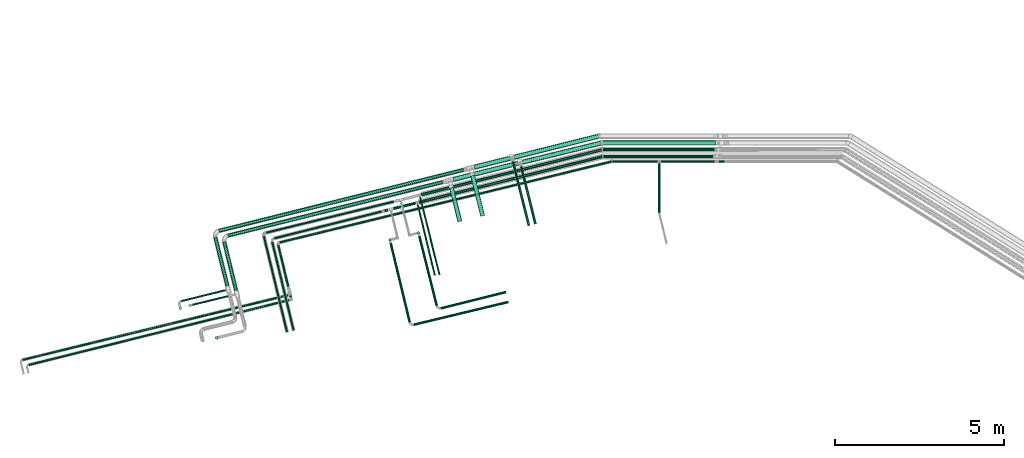
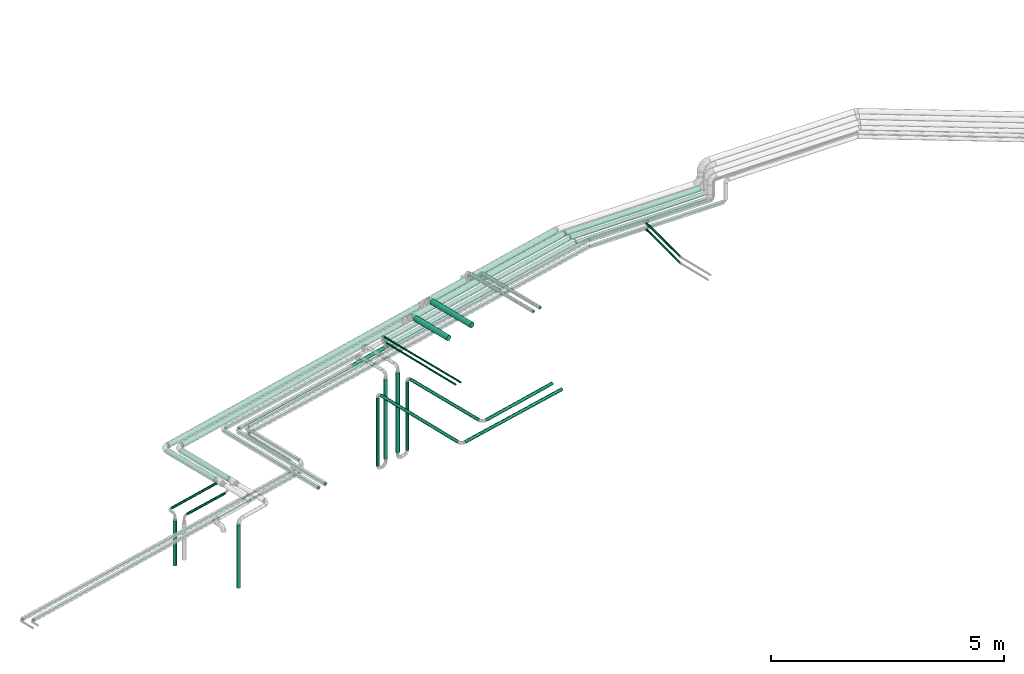
# One storey, part 42 of 93: 48 flow segments.
"""IFC2X3 building model written with IfcOpenShell, lengths in millimetres."""

from ifc_helpers import new_model, entity, si_unit, converted_unit, derived_unit, direction, frame, origin, origin_2d_with_axis, place, context, subcontext, project, spatial, polyline, circle, outline, extrude, type_object, element, save


model = new_model("IFC2X3")

# Units and contexts
model_context = context("Model", 3, precision=0.01, world=origin(), true_north=direction((6.12303176911189e-17, 1.0)))
body_context = subcontext(model_context, "Body", "Model", "MODEL_VIEW")
ifc_project = project(units=[si_unit("LENGTHUNIT", "METRE", prefix="MILLI"), si_unit("AREAUNIT", "SQUARE_METRE"), si_unit("VOLUMEUNIT", "CUBIC_METRE"), converted_unit("PLANEANGLEUNIT", "DEGREE", entity("IfcRatioMeasure", 0.0174532925199433), si_unit("PLANEANGLEUNIT", "RADIAN"), dimensions=[0, 0, 0, 0, 0, 0, 0]), si_unit("MASSUNIT", "GRAM", prefix="KILO"), derived_unit("MASSDENSITYUNIT", [(si_unit("MASSUNIT", "GRAM", prefix="KILO"), 1), (si_unit("LENGTHUNIT", "METRE"), -3)]), derived_unit("MOMENTOFINERTIAUNIT", [(si_unit("LENGTHUNIT", "METRE"), 4)]), si_unit("TIMEUNIT", "SECOND"), si_unit("FREQUENCYUNIT", "HERTZ"), si_unit("THERMODYNAMICTEMPERATUREUNIT", "DEGREE_CELSIUS"), derived_unit("THERMALTRANSMITTANCEUNIT", [(si_unit("MASSUNIT", "GRAM", prefix="KILO"), 1), (si_unit("THERMODYNAMICTEMPERATUREUNIT", "KELVIN"), -1), (si_unit("TIMEUNIT", "SECOND"), -3)]), derived_unit("VOLUMETRICFLOWRATEUNIT", [(si_unit("LENGTHUNIT", "METRE"), 3), (si_unit("TIMEUNIT", "SECOND"), -1)]), derived_unit("MASSFLOWRATEUNIT", [(si_unit("MASSUNIT", "GRAM", prefix="KILO"), 1), (si_unit("TIMEUNIT", "SECOND"), -1)]), derived_unit("ROTATIONALFREQUENCYUNIT", [(si_unit("TIMEUNIT", "SECOND"), -1)]), si_unit("ELECTRICCURRENTUNIT", "AMPERE"), si_unit("ELECTRICVOLTAGEUNIT", "VOLT"), si_unit("POWERUNIT", "WATT"), si_unit("FORCEUNIT", "NEWTON", prefix="KILO"), si_unit("ILLUMINANCEUNIT", "LUX"), si_unit("LUMINOUSFLUXUNIT", "LUMEN"), si_unit("LUMINOUSINTENSITYUNIT", "CANDELA"), derived_unit("USERDEFINED", [(si_unit("MASSUNIT", "GRAM", prefix="KILO"), -1), (si_unit("LENGTHUNIT", "METRE"), -2), (si_unit("TIMEUNIT", "SECOND"), 3), (si_unit("LUMINOUSFLUXUNIT", "LUMEN"), 1)]), derived_unit("LINEARVELOCITYUNIT", [(si_unit("LENGTHUNIT", "METRE"), 1), (si_unit("TIMEUNIT", "SECOND"), -1)]), si_unit("PRESSUREUNIT", "PASCAL"), derived_unit("USERDEFINED", [(si_unit("LENGTHUNIT", "METRE"), -2), (si_unit("MASSUNIT", "GRAM", prefix="KILO"), 1), (si_unit("TIMEUNIT", "SECOND"), -2)]), derived_unit("LINEARFORCEUNIT", [(si_unit("MASSUNIT", "GRAM", prefix="KILO"), 1), (si_unit("LENGTHUNIT", "METRE"), 1), (si_unit("TIMEUNIT", "SECOND"), -2), (si_unit("LENGTHUNIT", "METRE"), -1)]), derived_unit("PLANARFORCEUNIT", [(si_unit("MASSUNIT", "GRAM", prefix="KILO"), 1), (si_unit("LENGTHUNIT", "METRE"), 1), (si_unit("TIMEUNIT", "SECOND"), -2), (si_unit("LENGTHUNIT", "METRE"), -2)])], contexts=[model_context])

# Site, building, storey
site_placement = place(None, origin())
site = spatial("IfcSite", under=ifc_project, at=site_placement, CompositionType="ELEMENT")
building_placement = place(site_placement, origin())
building = spatial("IfcBuilding", under=site, at=building_placement, CompositionType="ELEMENT")
storey_placement = place(building_placement, frame((0.0, 0.0, -4200.0)))
storey = spatial("IfcBuildingStorey", under=building, at=storey_placement, CompositionType="ELEMENT", Elevation=-4200.0)

# Flow segments
pipe_segment_type_1 = type_object("IfcPipeSegmentType", PredefinedType="NOTDEFINED")
flow_segment_1_placement = place(storey_placement, frame((-7760.51, 13661.39, 2431.82)))
element("IfcFlowSegment", 1, at=flow_segment_1_placement, inside=storey, type_object=pipe_segment_type_1, context=body_context, shape_type="SweptSolid", body=[
    extrude(circle(Radius=66.5, at=origin_2d_with_axis()), frame((17.34, 66.2, 68.1), z_axis=(0.971553061175066, 0.236821975409198, 3.5841925034639e-05), x_axis=(-0.236821975561314, 0.971553061799116, 0.0)), (0.0, 0.0, 1.0), 2394.204717357),
])
flow_segment_2_placement = place(storey_placement, frame((-8003.53, 13808.11, 2431.9)))
element("IfcFlowSegment", 2, at=flow_segment_2_placement, inside=storey, type_object=pipe_segment_type_1, context=body_context, shape_type="SweptSolid", body=[
    extrude(circle(Radius=66.5, at=origin_2d_with_axis()), frame((17.68, 66.12, 68.1), z_axis=(0.970295726276005, 0.241921895599635, 0.0), x_axis=(-0.241921895599635, 0.970295726276005, 0.0)), (0.0, 0.0, 1.0), 2563.34327595366),
])
flow_segment_3_placement = place(storey_placement, frame((-9276.81, 12123.32, 2581.9)))
element("IfcFlowSegment", 3, at=flow_segment_3_placement, inside=storey, type_object=pipe_segment_type_1, context=body_context, shape_type="SweptSolid", body=[
    extrude(circle(Radius=66.5, at=origin_2d_with_axis()), frame((66.12, 1209.81, 68.1), z_axis=(0.241921895599647, -0.970295726276002, 0.0), x_axis=(-0.970295726276002, -0.241921895599647, 0.0)), (0.0, 0.0, 1.0), 1228.62727816467),
])
flow_segment_4_placement = place(storey_placement, frame((-16713.96, 11647.73, 2444.4)))
element("IfcFlowSegment", 4, at=flow_segment_4_placement, inside=storey, type_object=pipe_segment_type_1, context=body_context, shape_type="SweptSolid", body=[
    extrude(circle(Radius=54.0, at=origin_2d_with_axis()), frame((14.66, 53.99, 55.6), z_axis=(0.970295726275999, 0.241921895599659, 0.0), x_axis=(0.241921895599659, -0.970295726275999, 0.0)), (0.0, 0.0, 1.0), 7450.83630867599),
])
flow_segment_5_placement = place(storey_placement, frame((-16448.2, 11506.85, 2444.32)))
element("IfcFlowSegment", 5, at=flow_segment_5_placement, inside=storey, type_object=pipe_segment_type_1, context=body_context, shape_type="SweptSolid", body=[
    extrude(circle(Radius=54.0, at=origin_2d_with_axis()), frame((14.66, 53.99, 55.6), z_axis=(0.970295726276005, 0.241921895599632, 0.0), x_axis=(0.241921895599632, -0.970295726276005, 0.0)), (0.0, 0.0, 1.0), 6535.06575644785),
])
flow_segment_6_placement = place(storey_placement, frame((-9176.97, 13515.54, 2431.9)))
element("IfcFlowSegment", 6, at=flow_segment_6_placement, inside=storey, type_object=pipe_segment_type_1, context=body_context, shape_type="SweptSolid", body=[
    extrude(circle(Radius=66.5, at=origin_2d_with_axis()), frame((17.68, 66.12, 68.1), z_axis=(0.970295726276005, 0.241921895599634, 0.0), x_axis=(-0.241921895599634, 0.970295726276005, 0.0)), (0.0, 0.0, 1.0), 1079.36675916112),
])
flow_segment_7_placement = place(storey_placement, frame((-7817.34, 11902.18, 2669.9)))
element("IfcFlowSegment", 7, at=flow_segment_7_placement, inside=storey, type_object=pipe_segment_type_1, context=body_context, shape_type="SweptSolid", body=[
    extrude(circle(Radius=28.5, at=origin_2d_with_axis()), frame((29.25, 1736.92, 30.1), z_axis=(0.241921895599631, -0.970295726276006, 0.0), x_axis=(-0.970295726276006, -0.241921895599631, 0.0)), (0.0, 0.0, 1.0), 1781.33959077582),
])
flow_segment_8_placement = place(storey_placement, frame((-9799.79, 13153.11, 2431.82)))
element("IfcFlowSegment", 8, at=flow_segment_8_placement, inside=storey, type_object=pipe_segment_type_1, context=body_context, shape_type="SweptSolid", body=[
    extrude(circle(Radius=66.5, at=origin_2d_with_axis()), frame((17.68, 66.12, 68.1), z_axis=(0.970295726276005, 0.241921895599632, 0.0), x_axis=(0.241921895599632, -0.970295726276005, 0.0)), (0.0, 0.0, 1.0), 1971.35839123397),
])
flow_segment_9_placement = place(storey_placement, frame((-5347.47, 13853.91, 2457.55)))
element("IfcFlowSegment", 9, at=flow_segment_9_placement, inside=storey, type_object=pipe_segment_type_1, context=body_context, shape_type="SweptSolid", body=[
    extrude(circle(Radius=44.5, at=origin_2d_with_axis()), frame((0.0, 46.1, 46.1), z_axis=(1.0, 0.0, 0.0), x_axis=(0.0, 1.0, 0.0)), (0.0, 0.0, 1.0), 3236.37312185862),
])
flow_segment_10_placement = place(storey_placement, frame((-5367.0, 14053.91, 2454.21)))
element("IfcFlowSegment", 10, at=flow_segment_10_placement, inside=storey, type_object=pipe_segment_type_1, context=body_context, shape_type="SweptSolid", body=[
    extrude(circle(Radius=44.5, at=origin_2d_with_axis()), frame((0.0, 46.1, 46.1), z_axis=(1.0, 0.0, 0.0), x_axis=(0.0, 1.0, 0.0)), (0.0, 0.0, 1.0), 3293.65038874736),
])
flow_segment_11_placement = place(storey_placement, frame((-10745.01, 12721.09, 2454.21)))
element("IfcFlowSegment", 11, at=flow_segment_11_placement, inside=storey, type_object=pipe_segment_type_1, context=body_context, shape_type="SweptSolid", body=[
    extrude(circle(Radius=44.5, at=origin_2d_with_axis()), frame((12.36, 44.77, 46.1), z_axis=(0.970295726405392, 0.241921895080689, 0.0), x_axis=(0.241921895080689, -0.970295726405392, 0.0)), (0.0, 0.0, 1.0), 5499.99479458199),
])
flow_segment_12_placement = place(storey_placement, frame((-11821.04, 12248.14, 2457.18)))
element("IfcFlowSegment", 12, at=flow_segment_12_placement, inside=storey, type_object=pipe_segment_type_1, context=body_context, shape_type="SweptSolid", body=[
    extrude(circle(Radius=44.5, at=origin_2d_with_axis()), frame((12.36, 44.77, 46.1), z_axis=(0.970305319125472, 0.241883105093307, 0.000388776588564414), x_axis=(-0.241883123373291, 0.970305392454964, 0.0)), (0.0, 0.0, 1.0), 951.99240830168),
])
flow_segment_13_placement = place(storey_placement, frame((-11471.75, 11445.56, 445.0)))
element("IfcFlowSegment", 13, at=flow_segment_13_placement, inside=storey, type_object=pipe_segment_type_1, context=body_context, shape_type="SweptSolid", body=[
    extrude(circle(Radius=44.5, at=origin_2d_with_axis()), frame((46.1, 46.1, 0.0)), (0.0, 0.0, 1.0), 2079.99622186092),
])
flow_segment_14_placement = place(storey_placement, frame((-11691.67, 11396.84, 370.0)))
element("IfcFlowSegment", 14, at=flow_segment_14_placement, inside=storey, type_object=pipe_segment_type_1, context=body_context, shape_type="SweptSolid", body=[
    extrude(circle(Radius=38.0, at=origin_2d_with_axis()), frame((39.6, 39.6, 0.0), z_axis=(0.0, 0.0, 1.0), x_axis=(-1.0, 0.0, 0.0)), (0.0, 0.0, 1.0), 1780.00000000002),
])
flow_segment_15_placement = place(storey_placement, frame((-11124.1, 11530.35, 435.0)))
element("IfcFlowSegment", 15, at=flow_segment_15_placement, inside=storey, type_object=pipe_segment_type_1, context=body_context, shape_type="SweptSolid", body=[
    extrude(circle(Radius=44.5, at=origin_2d_with_axis()), frame((46.1, 46.1, 0.0)), (0.0, 0.0, 1.0), 2090.00049979827),
])
flow_segment_16_placement = place(storey_placement, frame((-10845.57, 11603.16, 360.0)))
element("IfcFlowSegment", 16, at=flow_segment_16_placement, inside=storey, type_object=pipe_segment_type_1, context=body_context, shape_type="SweptSolid", body=[
    extrude(circle(Radius=38.0, at=origin_2d_with_axis()), frame((39.6, 39.6, 0.0), z_axis=(0.0, 0.0, 1.0), x_axis=(-1.0, 0.0, 0.0)), (0.0, 0.0, 1.0), 1790.00217727136),
])
flow_segment_17_placement = place(storey_placement, frame((-10820.22, 9478.01, 2210.41)))
element("IfcFlowSegment", 17, at=flow_segment_17_placement, inside=storey, type_object=pipe_segment_type_1, context=body_context, shape_type="SweptSolid", body=[
    extrude(circle(Radius=38.0, at=origin_2d_with_axis()), frame((551.77, 10.8, 39.6), z_axis=(-0.242124380835317, 0.970245218594307, 0.0), x_axis=(-0.970245218594307, -0.242124380835317, 0.0)), (0.0, 0.0, 1.0), 2120.00000000001),
])
flow_segment_18_placement = place(storey_placement, frame((-10158.01, 9377.53, 2210.41)))
element("IfcFlowSegment", 18, at=flow_segment_18_placement, inside=storey, type_object=pipe_segment_type_1, context=body_context, shape_type="SweptSolid", body=[
    extrude(circle(Radius=38.0, at=origin_2d_with_axis()), frame((10.8, 38.46, 39.6), z_axis=(0.970245218594304, 0.242124380835327, 0.0), x_axis=(0.242124380835327, -0.970245218594304, 0.0)), (0.0, 0.0, 1.0), 1980.00000000001),
])
flow_segment_19_placement = place(storey_placement, frame((-11667.24, 8995.24, 2210.41)))
element("IfcFlowSegment", 19, at=flow_segment_19_placement, inside=storey, type_object=pipe_segment_type_1, context=body_context, shape_type="SweptSolid", body=[
    extrude(circle(Radius=38.0, at=origin_2d_with_axis()), frame((599.63, 10.48, 39.6), z_axis=(-0.233787062942979, 0.972287822201068, 0.0), x_axis=(-0.972287822201068, -0.233787062942979, 0.0)), (0.0, 0.0, 1.0), 2400.00000000002),
])
flow_segment_20_placement = place(storey_placement, frame((-10957.48, 8893.32, 2210.41)))
element("IfcFlowSegment", 20, at=flow_segment_20_placement, inside=storey, type_object=pipe_segment_type_1, context=body_context, shape_type="SweptSolid", body=[
    extrude(circle(Radius=38.0, at=origin_2d_with_axis()), frame((10.48, 38.54, 39.6), z_axis=(0.972287822201067, 0.233787062942985, 0.0), x_axis=(0.233787062942985, -0.972287822201067, 0.0)), (0.0, 0.0, 1.0), 2873.30751103441),
])
flow_segment_21_placement = place(storey_placement, frame((-9900.25, 11955.75, 2581.91)))
element("IfcFlowSegment", 21, at=flow_segment_21_placement, inside=storey, type_object=pipe_segment_type_1, context=body_context, shape_type="SweptSolid", body=[
    extrude(circle(Radius=66.5, at=origin_2d_with_axis()), frame((66.12, 1014.71, 68.1), z_axis=(0.241896757659001, -0.970301993522667, 0.0), x_axis=(0.970301993522667, 0.241896757659001, 0.0)), (0.0, 0.0, 1.0), 1027.54950961074),
])
flow_segment_22_placement = place(storey_placement, frame((-8060.02, 11853.8, 2669.9)))
element("IfcFlowSegment", 22, at=flow_segment_22_placement, inside=storey, type_object=pipe_segment_type_1, context=body_context, shape_type="SweptSolid", body=[
    extrude(circle(Radius=28.5, at=origin_2d_with_axis()), frame((29.25, 1931.93, 30.1), z_axis=(0.241921895599632, -0.970295726276005, 0.0), x_axis=(-0.970295726276005, -0.241921895599632, 0.0)), (0.0, 0.0, 1.0), 1982.32667790187),
])
flow_segment_23_placement = place(storey_placement, frame((-10814.84, 12498.98, 2457.55)))
element("IfcFlowSegment", 23, at=flow_segment_23_placement, inside=storey, type_object=pipe_segment_type_1, context=body_context, shape_type="SweptSolid", body=[
    extrude(circle(Radius=44.5, at=origin_2d_with_axis()), frame((12.36, 44.77, 46.1), z_axis=(0.970302633072812, 0.241894192265893, 0.0), x_axis=(-0.241894192265893, 0.970302633072812, 0.0)), (0.0, 0.0, 1.0), 5592.05871780592),
])
flow_segment_24_placement = place(storey_placement, frame((-5372.07, 14231.91, 2431.9)))
element("IfcFlowSegment", 24, at=flow_segment_24_placement, inside=storey, type_object=pipe_segment_type_1, context=body_context, shape_type="SweptSolid", body=[
    extrude(circle(Radius=66.5, at=origin_2d_with_axis()), frame((0.0, 68.1, 68.1), z_axis=(1.0, 0.0, 0.0), x_axis=(0.0, -1.0, 0.0)), (0.0, 0.0, 1.0), 3329.8857023589),
])
flow_segment_25_placement = place(storey_placement, frame((-16596.85, 9926.05, 2444.32)))
element("IfcFlowSegment", 25, at=flow_segment_25_placement, inside=storey, type_object=pipe_segment_type_1, context=body_context, shape_type="SweptSolid", body=[
    extrude(circle(Radius=54.0, at=origin_2d_with_axis()), frame((54.05, 1452.96, 55.6), z_axis=(0.237217705772623, -0.971456428815589, 0.000408632885785687), x_axis=(-0.971456509922902, -0.237217725578031, 0.0)), (0.0, 0.0, 1.0), 1480.82099803477),
])
flow_segment_26_placement = place(storey_placement, frame((-16862.54, 10059.59, 2444.4)))
element("IfcFlowSegment", 26, at=flow_segment_26_placement, inside=storey, type_object=pipe_segment_type_1, context=body_context, shape_type="SweptSolid", body=[
    extrude(circle(Radius=54.0, at=origin_2d_with_axis()), frame((53.99, 1460.3, 55.6), z_axis=(0.242135671523188, -0.970242400937011, 0.0), x_axis=(-0.970242400937011, -0.242135671523188, 0.0)), (0.0, 0.0, 1.0), 1489.96956280194),
])
flow_segment_27_placement = place(storey_placement, frame((-16814.92, 8495.47, 730.0)))
element("IfcFlowSegment", 27, at=flow_segment_27_placement, inside=storey, type_object=pipe_segment_type_1, context=body_context, shape_type="SweptSolid", body=[
    extrude(outline(polyline([(-5.81, -44.12), (5.81, -44.12), (17.03, -41.11), (27.09, -35.3), (35.3, -27.09), (41.11, -17.03), (44.12, -5.81), (44.12, 5.81), (41.11, 17.03), (35.3, 27.09), (27.09, 35.3), (17.03, 41.11), (5.81, 44.12), (-5.81, 44.12), (-17.03, 41.11), (-27.09, 35.3), (-35.3, 27.09), (-41.11, 17.03), (-44.12, 5.81), (-44.12, -5.81), (-41.11, -17.03), (-35.3, -27.09), (-27.09, -35.3), (-17.03, -41.11), (-5.81, -44.12)])), frame((46.1, 46.1, 0.0), z_axis=(-2.50264558436275e-09, 1.00284373833102e-08, 1.0), x_axis=(-0.130526192220128, 0.9914448613738, -1.02693035098952e-08)), (0.0, 0.0, 1.0), 1650.60511215779),
])
pipe_segment_type_2 = type_object("IfcPipeSegmentType", PredefinedType="NOTDEFINED")
flow_segment_28_placement = place(storey_placement, frame((-15082.34, 11448.1, 2468.4)))
element("IfcFlowSegment", 28, at=flow_segment_28_placement, inside=storey, type_object=pipe_segment_type_2, context=body_context, shape_type="SweptSolid", body=[
    extrude(circle(Radius=30.0, at=origin_2d_with_axis()), frame((8.85, 30.7, 31.61), z_axis=(0.970288537655733, 0.241950725704179, -5.01200914775057e-06), x_axis=(0.241950725707218, -0.97028853766792, 0.0)), (0.0, 0.0, 1.0), 3275.77869410409),
])
flow_segment_29_placement = place(storey_placement, frame((-15328.67, 11612.3, 2469.24)))
element("IfcFlowSegment", 29, at=flow_segment_29_placement, inside=storey, type_object=pipe_segment_type_2, context=body_context, shape_type="SweptSolid", body=[
    extrude(circle(Radius=30.0, at=origin_2d_with_axis()), frame((8.7, 30.74, 31.6), z_axis=(0.971551075195952, 0.236830125178739, 9.66501229446896e-06), x_axis=(0.2368301251898, -0.97155107524133, 0.0)), (0.0, 0.0, 1.0), 3891.90294438014),
])
flow_segment_30_placement = place(storey_placement, frame((-5093.23, 13724.41, 2367.25)))
element("IfcFlowSegment", 30, at=flow_segment_30_placement, inside=storey, type_object=pipe_segment_type_2, context=body_context, shape_type="SweptSolid", body=[
    extrude(circle(Radius=24.0, at=origin_2d_with_axis()), frame((0.0, 25.6, 25.6), z_axis=(1.0, 0.0, 0.0), x_axis=(0.0, 1.0, 0.0)), (0.0, 0.0, 1.0), 1333.38964173774),
])
flow_segment_31_placement = place(storey_placement, frame((-14916.19, 11334.04, 2367.25)))
element("IfcFlowSegment", 31, at=flow_segment_31_placement, inside=storey, type_object=pipe_segment_type_2, context=body_context, shape_type="SweptSolid", body=[
    extrude(circle(Radius=24.0, at=origin_2d_with_axis()), frame((7.28, 24.91, 25.6), z_axis=(0.971551074149835, 0.23683012966745, 0.0), x_axis=(-0.23683012966745, 0.971551074149835, 0.0)), (0.0, 0.0, 1.0), 10089.2038362497),
])
flow_segment_32_placement = place(storey_placement, frame((-3645.84, 13724.41, 2533.21)))
element("IfcFlowSegment", 32, at=flow_segment_32_placement, inside=storey, type_object=pipe_segment_type_2, context=body_context, shape_type="SweptSolid", body=[
    extrude(circle(Radius=24.0, at=origin_2d_with_axis()), frame((0.0, 25.6, 25.6), z_axis=(1.0, 0.0, 0.0), x_axis=(0.0, -1.0, 0.0)), (0.0, 0.0, 1.0), 1583.00000000001),
])
flow_segment_33_placement = place(storey_placement, frame((-14975.76, 10039.51, 2367.25)))
element("IfcFlowSegment", 33, at=flow_segment_33_placement, inside=storey, type_object=pipe_segment_type_2, context=body_context, shape_type="SweptSolid", body=[
    extrude(circle(Radius=24.0, at=origin_2d_with_axis()), frame((324.05, 7.21, 25.6), z_axis=(-0.233868385495283, 0.972268264557591, 0.0), x_axis=(0.972268264557591, 0.233868385495283, 0.0)), (0.0, 0.0, 1.0), 1278.99033837842),
])
flow_segment_34_placement = place(storey_placement, frame((-14975.78, 9724.02, 2533.21)))
element("IfcFlowSegment", 34, at=flow_segment_34_placement, inside=storey, type_object=pipe_segment_type_2, context=body_context, shape_type="SweptSolid", body=[
    extrude(circle(Radius=24.0, at=origin_2d_with_axis()), frame((24.93, 1566.32, 25.6), z_axis=(0.233646720181625, -0.9723215569699, 0.0), x_axis=(0.9723215569699, 0.233646720181625, 0.0)), (0.0, 0.0, 1.0), 1603.49585906828),
])
flow_segment_35_placement = place(storey_placement, frame((-15405.83, 8701.37, 2469.24)))
element("IfcFlowSegment", 35, at=flow_segment_35_placement, inside=storey, type_object=pipe_segment_type_2, context=body_context, shape_type="SweptSolid", body=[
    extrude(circle(Radius=30.0, at=origin_2d_with_axis()), frame((30.75, 2851.04, 31.6), z_axis=(0.235134964159685, -0.971962730062024, 0.0), x_axis=(-0.971962730062024, -0.235134964159685, 0.0)), (0.0, 0.0, 1.0), 2924.38590899746),
])
flow_segment_36_placement = place(storey_placement, frame((-15159.72, 8748.42, 2468.14)))
element("IfcFlowSegment", 36, at=flow_segment_36_placement, inside=storey, type_object=pipe_segment_type_2, context=body_context, shape_type="SweptSolid", body=[
    extrude(circle(Radius=30.0, at=origin_2d_with_axis()), frame((666.78, 8.65, 31.6), z_axis=(-0.235049086006716, 0.971983496111961, 0.000102241762859156), x_axis=(-0.971983501192216, -0.235049087235244, 0.0)), (0.0, 0.0, 1.0), 2705.9395518919),
])
flow_segment_37_placement = place(storey_placement, frame((-10854.61, 10384.35, 2627.25)))
element("IfcFlowSegment", 37, at=flow_segment_37_placement, inside=storey, type_object=pipe_segment_type_2, context=body_context, shape_type="SweptSolid", body=[
    extrude(circle(Radius=21.15, at=origin_2d_with_axis()), frame((528.22, 6.56, 22.75), z_axis=(-0.234708366892979, 0.972065832395333, 0.0), x_axis=(-0.972065832395333, -0.234708366892979, 0.0)), (0.0, 0.0, 1.0), 2156.13355399758),
])
flow_segment_38_placement = place(storey_placement, frame((-22511.36, 7866.67, 2267.25)))
element("IfcFlowSegment", 38, at=flow_segment_38_placement, inside=storey, type_object=pipe_segment_type_2, context=body_context, shape_type="SweptSolid", body=[
    extrude(circle(Radius=24.0, at=origin_2d_with_axis()), frame((7.28, 24.91, 25.6), z_axis=(0.971553776633291, 0.236819042962322, 0.0), x_axis=(-0.236819042962322, 0.971553776633291, 0.0)), (0.0, 0.0, 1.0), 8081.84246750568),
])
flow_segment_39_placement = place(storey_placement, frame((-22326.07, 7717.18, 2267.25)))
element("IfcFlowSegment", 39, at=flow_segment_39_placement, inside=storey, type_object=pipe_segment_type_2, context=body_context, shape_type="SweptSolid", body=[
    extrude(circle(Radius=24.0, at=origin_2d_with_axis()), frame((7.4, 24.88, 25.6), z_axis=(0.970295726276022, 0.241921895599564, 0.0), x_axis=(-0.241921895599564, 0.970295726276022, 0.0)), (0.0, 0.0, 1.0), 7936.21539652437),
])
flow_segment_40_placement = place(storey_placement, frame((-3728.44, 12232.9, 2533.21)))
element("IfcFlowSegment", 40, at=flow_segment_40_placement, inside=storey, type_object=pipe_segment_type_2, context=body_context, shape_type="SweptSolid", body=[
    extrude(circle(Radius=24.0, at=origin_2d_with_axis()), frame((25.6, 0.0, 25.6), z_axis=(0.0, 1.0, 0.0), x_axis=(-1.0, 0.0, 0.0)), (0.0, 0.0, 1.0), 1460.10325980172),
])
flow_segment_41_placement = place(storey_placement, frame((-5093.58, 13724.41, 2533.21)))
element("IfcFlowSegment", 41, at=flow_segment_41_placement, inside=storey, type_object=pipe_segment_type_2, context=body_context, shape_type="SweptSolid", body=[
    extrude(circle(Radius=24.0, at=origin_2d_with_axis()), frame((0.0, 25.6, 25.6), z_axis=(1.0, 0.0, 0.0), x_axis=(0.0, -1.0, 0.0)), (0.0, 0.0, 1.0), 1333.74030890236),
])
flow_segment_42_placement = place(storey_placement, frame((-3728.44, 12232.89, 2367.25)))
element("IfcFlowSegment", 42, at=flow_segment_42_placement, inside=storey, type_object=pipe_segment_type_2, context=body_context, shape_type="SweptSolid", body=[
    extrude(circle(Radius=24.0, at=origin_2d_with_axis()), frame((25.6, 0.0, 25.6), z_axis=(0.0, 1.0, 0.0), x_axis=(-1.0, 0.0, 0.0)), (0.0, 0.0, 1.0), 1460.10658171963),
])
flow_segment_43_placement = place(storey_placement, frame((-3645.84, 13724.41, 2367.25)))
element("IfcFlowSegment", 43, at=flow_segment_43_placement, inside=storey, type_object=pipe_segment_type_2, context=body_context, shape_type="SweptSolid", body=[
    extrude(circle(Radius=24.0, at=origin_2d_with_axis()), frame((0.0, 25.6, 25.6), z_axis=(1.0, 0.0, 0.0), x_axis=(0.0, -1.0, 0.0)), (0.0, 0.0, 1.0), 1883.00000000001),
])
flow_segment_44_placement = place(storey_placement, frame((-10784.39, 10400.28, 2627.25)))
element("IfcFlowSegment", 44, at=flow_segment_44_placement, inside=storey, type_object=pipe_segment_type_2, context=body_context, shape_type="SweptSolid", body=[
    extrude(circle(Radius=21.15, at=origin_2d_with_axis()), frame((22.12, 2308.73, 22.75), z_axis=(0.24192724864441, -0.970294391596358, 0.0), x_axis=(-0.970294391596358, -0.24192724864441, 0.0)), (0.0, 0.0, 1.0), 2372.49695482888),
])
flow_segment_45_placement = place(storey_placement, frame((-14916.21, 11334.12, 2533.21)))
element("IfcFlowSegment", 45, at=flow_segment_45_placement, inside=storey, type_object=pipe_segment_type_2, context=body_context, shape_type="SweptSolid", body=[
    extrude(circle(Radius=24.0, at=origin_2d_with_axis()), frame((7.28, 24.91, 25.6), z_axis=(0.971551074149834, 0.236830129667456, 0.0), x_axis=(0.236830129667456, -0.971551074149834, 0.0)), (0.0, 0.0, 1.0), 10088.8628906297),
])
flow_segment_46_placement = place(storey_placement, frame((-17821.98, 9594.6, 2468.4)))
element("IfcFlowSegment", 46, at=flow_segment_46_placement, inside=storey, type_object=pipe_segment_type_2, context=body_context, shape_type="SweptSolid", body=[
    extrude(circle(Radius=30.0, at=origin_2d_with_axis()), frame((8.86, 30.7, 31.6), z_axis=(0.970242400937011, 0.242135671523189, 0.0), x_axis=(0.242135671523189, -0.970242400937011, 0.0)), (0.0, 0.0, 1.0), 1344.41930470671),
])
flow_segment_47_placement = place(storey_placement, frame((-17884.3, 9367.0, 1160.0)))
element("IfcFlowSegment", 47, at=flow_segment_47_placement, inside=storey, type_object=pipe_segment_type_2, context=body_context, shape_type="SweptSolid", body=[
    extrude(circle(Radius=44.25, at=origin_2d_with_axis()), frame((45.85, 45.85, 0.0)), (0.0, 0.0, 1.0), 1174.99999999999),
])
flow_segment_48_placement = place(storey_placement, frame((-17496.04, 9485.49, 2268.4)))
element("IfcFlowSegment", 48, at=flow_segment_48_placement, inside=storey, type_object=pipe_segment_type_2, context=body_context, shape_type="SweptSolid", body=[
    extrude(circle(Radius=30.0, at=origin_2d_with_axis()), frame((8.72, 30.74, 31.6), z_axis=(0.971387876440469, 0.237498617900138, 0.0), x_axis=(0.237498617900138, -0.971387876440469, 0.0)), (0.0, 0.0, 1.0), 1127.40710888161),
])

save(model, "model.ifc")
